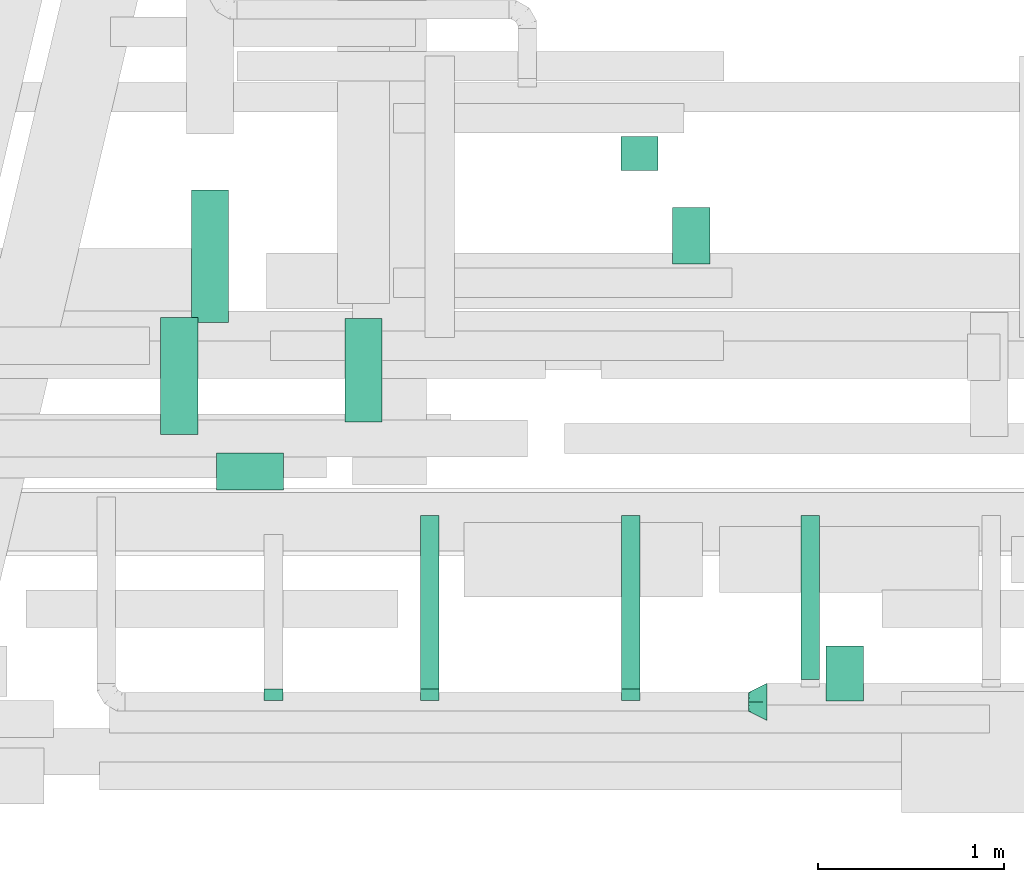
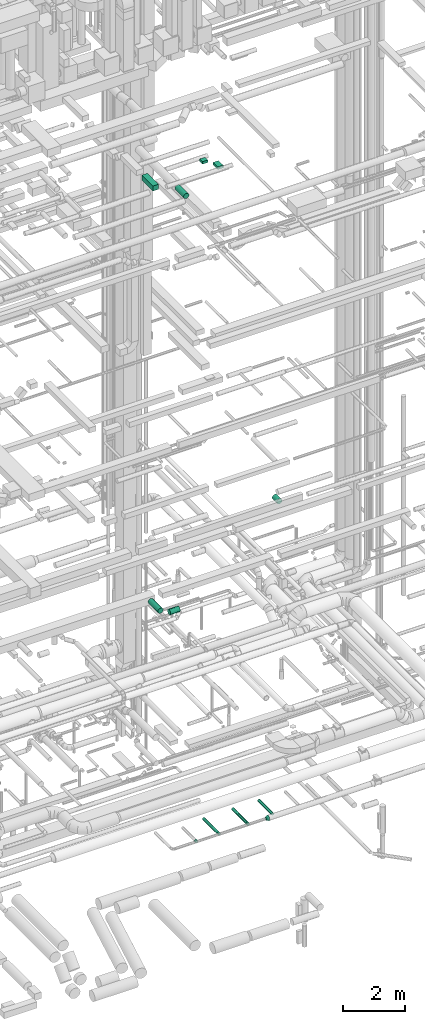
# One storey, part 205 of 337: 10 flow segments, 4 flow fittings.
"""IFC2X3 building model written with IfcOpenShell, lengths in millimetres."""

from ifc_helpers import new_model, entity, si_unit, converted_unit, derived_unit, direction, frame, origin, origin_2d_with_axis, place, context, subcontext, project, spatial, rectangle, circle, extrude, faceted_brep, source, transform, mapped, material, type_object, type_shapes, element, save


model = new_model("IFC2X3")

# Units and contexts
model_context = context("Model", 3, precision=0.01, world=origin(), true_north=direction((6.12303176911189e-17, 1.0)))
body_context = subcontext(model_context, "Body", "Model", "MODEL_VIEW")
ifc_project = project(units=[si_unit("LENGTHUNIT", "METRE", prefix="MILLI"), si_unit("AREAUNIT", "SQUARE_METRE"), si_unit("VOLUMEUNIT", "CUBIC_METRE"), converted_unit("PLANEANGLEUNIT", "DEGREE", entity("IfcRatioMeasure", 0.0174532925199433), si_unit("PLANEANGLEUNIT", "RADIAN"), dimensions=[0, 0, 0, 0, 0, 0, 0]), si_unit("MASSUNIT", "GRAM", prefix="KILO"), derived_unit("MASSDENSITYUNIT", [(si_unit("MASSUNIT", "GRAM", prefix="KILO"), 1), (si_unit("LENGTHUNIT", "METRE"), -3)]), derived_unit("MOMENTOFINERTIAUNIT", [(si_unit("LENGTHUNIT", "METRE"), 4)]), si_unit("TIMEUNIT", "SECOND"), si_unit("FREQUENCYUNIT", "HERTZ"), si_unit("THERMODYNAMICTEMPERATUREUNIT", "DEGREE_CELSIUS"), derived_unit("THERMALTRANSMITTANCEUNIT", [(si_unit("MASSUNIT", "GRAM", prefix="KILO"), 1), (si_unit("THERMODYNAMICTEMPERATUREUNIT", "KELVIN"), -1), (si_unit("TIMEUNIT", "SECOND"), -3)]), derived_unit("VOLUMETRICFLOWRATEUNIT", [(si_unit("LENGTHUNIT", "METRE"), 3), (si_unit("TIMEUNIT", "SECOND"), -1)]), derived_unit("MASSFLOWRATEUNIT", [(si_unit("MASSUNIT", "GRAM", prefix="KILO"), 1), (si_unit("TIMEUNIT", "SECOND"), -1)]), derived_unit("ROTATIONALFREQUENCYUNIT", [(si_unit("TIMEUNIT", "SECOND"), -1)]), si_unit("ELECTRICCURRENTUNIT", "AMPERE"), si_unit("ELECTRICVOLTAGEUNIT", "VOLT"), si_unit("POWERUNIT", "WATT"), si_unit("FORCEUNIT", "NEWTON", prefix="KILO"), si_unit("ILLUMINANCEUNIT", "LUX"), si_unit("LUMINOUSFLUXUNIT", "LUMEN"), si_unit("LUMINOUSINTENSITYUNIT", "CANDELA"), derived_unit("USERDEFINED", [(si_unit("MASSUNIT", "GRAM", prefix="KILO"), -1), (si_unit("LENGTHUNIT", "METRE"), -2), (si_unit("TIMEUNIT", "SECOND"), 3), (si_unit("LUMINOUSFLUXUNIT", "LUMEN"), 1)]), derived_unit("LINEARVELOCITYUNIT", [(si_unit("LENGTHUNIT", "METRE"), 1), (si_unit("TIMEUNIT", "SECOND"), -1)]), si_unit("PRESSUREUNIT", "PASCAL"), derived_unit("USERDEFINED", [(si_unit("LENGTHUNIT", "METRE"), -2), (si_unit("MASSUNIT", "GRAM", prefix="KILO"), 1), (si_unit("TIMEUNIT", "SECOND"), -2)]), derived_unit("LINEARFORCEUNIT", [(si_unit("MASSUNIT", "GRAM", prefix="KILO"), 1), (si_unit("LENGTHUNIT", "METRE"), 1), (si_unit("TIMEUNIT", "SECOND"), -2), (si_unit("LENGTHUNIT", "METRE"), -1)]), derived_unit("PLANARFORCEUNIT", [(si_unit("MASSUNIT", "GRAM", prefix="KILO"), 1), (si_unit("LENGTHUNIT", "METRE"), 1), (si_unit("TIMEUNIT", "SECOND"), -2), (si_unit("LENGTHUNIT", "METRE"), -2)])], contexts=[model_context])

# Site, building, storey
site_placement = place(None, origin())
site = spatial("IfcSite", under=ifc_project, at=site_placement, CompositionType="ELEMENT")
building_placement = place(site_placement, origin())
building = spatial("IfcBuilding", under=site, at=building_placement, CompositionType="ELEMENT")
storey_placement = place(building_placement, origin())
storey = spatial("IfcBuildingStorey", under=building, at=storey_placement, CompositionType="ELEMENT", Elevation=0.0)

# Flow segments
duct_segment_type_1 = type_object("IfcDuctSegmentType", PredefinedType="NOTDEFINED")
flow_segment_1_placement = place(storey_placement, frame((55079.59, 2900.97, 27450.0)))
element("IfcFlowSegment", 1, at=flow_segment_1_placement, inside=storey, type_object=duct_segment_type_1, context=body_context, shape_type="SweptSolid", body=[
    extrude(rectangle(XDim=711.276811598477, YDim=199.999999999998, at=origin_2d_with_axis()), frame((100.0, 355.64, 0.0), z_axis=(0.0, 0.0, 1.0), x_axis=(0.0, -1.0, 0.0)), (0.0, 0.0, 1.0), 199.999999999998),
])
flow_segment_2_placement = place(storey_placement, frame((57664.94, 3214.24, 27200.0)))
element("IfcFlowSegment", 2, at=flow_segment_2_placement, inside=storey, type_object=duct_segment_type_1, context=body_context, shape_type="SweptSolid", body=[
    extrude(rectangle(XDim=303.509978559031, YDim=199.999999999998, at=origin_2d_with_axis()), frame((100.0, 151.75, 0.0), z_axis=(0.0, 0.0, 1.0), x_axis=(0.0, 1.0, 0.0)), (0.0, 0.0, 1.0), 100.000000000003),
])
flow_segment_3_placement = place(storey_placement, frame((57387.09, 3718.31, 27200.0)))
element("IfcFlowSegment", 3, at=flow_segment_3_placement, inside=storey, type_object=duct_segment_type_1, context=body_context, shape_type="SweptSolid", body=[
    extrude(rectangle(XDim=179.999999999986, YDim=199.999999999998, at=origin_2d_with_axis()), frame((100.0, 90.0, 0.0), z_axis=(0.0, 0.0, 1.0), x_axis=(0.0, -1.0, 0.0)), (0.0, 0.0, 1.0), 100.000000000003),
])
duct_segment_type_2 = type_object("IfcDuctSegmentType", PredefinedType="NOTDEFINED")
flow_segment_4_placement = place(storey_placement, frame((55214.11, 1997.57, 11298.4)))
element("IfcFlowSegment", 4, at=flow_segment_4_placement, inside=storey, type_object=duct_segment_type_2, context=body_context, shape_type="SweptSolid", body=[
    extrude(circle(Radius=100.0, at=origin_2d_with_axis()), frame((0.0, 101.6, 101.6), z_axis=(1.0, 0.0, 0.0), x_axis=(0.0, -1.0, 0.0)), (0.0, 0.0, 1.0), 359.999999999961),
])
flow_segment_5_placement = place(storey_placement, frame((54912.51, 2299.16, 11298.4)))
element("IfcFlowSegment", 5, at=flow_segment_5_placement, inside=storey, type_object=duct_segment_type_2, context=body_context, shape_type="SweptSolid", body=[
    extrude(circle(Radius=100.0, at=origin_2d_with_axis()), frame((101.6, 0.0, 101.6), z_axis=(0.0, 1.0, 0.0), x_axis=(-1.0, 0.0, 0.0)), (0.0, 0.0, 1.0), 628.712130819277),
])
flow_segment_6_placement = place(storey_placement, frame((58488.6, 865.66, 15198.4)))
element("IfcFlowSegment", 6, at=flow_segment_6_placement, inside=storey, type_object=duct_segment_type_2, context=body_context, shape_type="SweptSolid", body=[
    extrude(circle(Radius=100.0, at=origin_2d_with_axis()), frame((101.6, 0.0, 101.6), z_axis=(0.0, 1.0, 0.0), x_axis=(-1.0, 0.0, 0.0)), (0.0, 0.0, 1.0), 296.742634045113),
])
flow_segment_7_placement = place(storey_placement, frame((55903.34, 2365.61, 27158.4)))
element("IfcFlowSegment", 7, at=flow_segment_7_placement, inside=storey, type_object=duct_segment_type_2, context=body_context, shape_type="SweptSolid", body=[
    extrude(circle(Radius=100.0, at=origin_2d_with_axis()), frame((101.6, 0.0, 101.6), z_axis=(0.0, 1.0, 0.0), x_axis=(-1.0, 0.0, 0.0)), (0.0, 0.0, 1.0), 557.500000000001),
])
flow_segment_8_placement = place(storey_placement, frame((56309.27, 932.18, 2998.4)))
element("IfcFlowSegment", 8, at=flow_segment_8_placement, inside=storey, type_object=duct_segment_type_2, context=body_context, shape_type="SweptSolid", body=[
    extrude(circle(Radius=50.0, at=origin_2d_with_axis()), frame((51.6, 0.0, 51.6), z_axis=(0.0, 1.0, 0.0), x_axis=(1.0, 0.0, 0.0)), (0.0, 0.0, 1.0), 930.000000000234),
])
flow_segment_9_placement = place(storey_placement, frame((57389.27, 932.18, 2998.4)))
element("IfcFlowSegment", 9, at=flow_segment_9_placement, inside=storey, type_object=duct_segment_type_2, context=body_context, shape_type="SweptSolid", body=[
    extrude(circle(Radius=50.0, at=origin_2d_with_axis()), frame((51.6, 0.0, 51.6), z_axis=(0.0, 1.0, 0.0), x_axis=(1.0, 0.0, 0.0)), (0.0, 0.0, 1.0), 930.000000000324),
])
flow_segment_10_placement = place(storey_placement, frame((58353.51, 982.18, 2998.4)))
element("IfcFlowSegment", 10, at=flow_segment_10_placement, inside=storey, type_object=duct_segment_type_2, context=body_context, shape_type="SweptSolid", body=[
    extrude(circle(Radius=50.0, at=origin_2d_with_axis()), frame((51.6, 0.0, 51.6), z_axis=(0.0, 1.0, 0.0), x_axis=(1.0, 0.0, 0.0)), (0.0, 0.0, 1.0), 880.000000000402),
])

# Flow fittings
ifc_material = material()
duct_fitting_type_1 = type_object("IfcDuctFittingType", PredefinedType="NOTDEFINED", material=ifc_material)
shared_shape_1 = source(origin(), body_context, "Body", "Brep", [
    faceted_brep([(20.0, 0.0, -50.0), (20.0, 12.94, -48.3), (20.0, 25.0, -43.3), (20.0, 35.36, -35.36), (20.0, 43.3, -25.0), (20.0, 48.3, -12.94), (20.0, 50.0, 0.0), (20.0, 48.3, 12.94), (20.0, 43.3, 25.0), (20.0, 35.36, 35.36), (20.0, 25.0, 43.3), (20.0, 12.94, 48.3), (20.0, 0.0, 50.0), (20.0, -12.94, 48.3), (20.0, -25.0, 43.3), (20.0, -35.36, 35.36), (20.0, -43.3, 25.0), (20.0, -48.3, 12.94), (20.0, -50.0, 0.0), (20.0, -48.3, -12.94), (20.0, -43.3, -25.0), (20.0, -35.36, -35.36), (20.0, -25.0, -43.3), (20.0, -12.94, -48.3), (0.0, 0.0, 50.0), (-43.9, 0.0, 50.0), (-43.9, -12.94, 48.3), (0.0, -12.94, 48.3), (-43.9, -25.0, 43.3), (0.0, -25.0, 43.3), (0.0, -35.36, 35.36), (-43.9, -35.36, 35.36), (0.0, -43.3, 25.0), (-43.9, -43.3, 25.0), (-43.9, -48.3, 12.94), (0.0, -48.3, 12.94), (-43.9, -50.0, 0.0), (0.0, -50.0, 0.0), (-43.9, -48.3, -12.94), (0.0, -48.3, -12.94), (-43.9, -43.3, -25.0), (0.0, -43.3, -25.0), (0.0, -35.36, -35.36), (-43.9, -35.36, -35.36), (0.0, -25.0, -43.3), (-43.9, -25.0, -43.3), (-43.9, -12.94, -48.3), (0.0, -12.94, -48.3), (-43.9, 0.0, -50.0), (0.0, 0.0, -50.0), (-43.9, 12.94, -48.3), (0.0, 12.94, -48.3), (-43.9, 25.0, -43.3), (0.0, 25.0, -43.3), (0.0, 35.36, -35.36), (-43.9, 35.36, -35.36), (0.0, 43.3, -25.0), (-43.9, 43.3, -25.0), (-43.9, 48.3, -12.94), (0.0, 48.3, -12.94), (-43.9, 50.0, 0.0), (0.0, 50.0, 0.0), (-43.9, 48.3, 12.94), (0.0, 48.3, 12.94), (-43.9, 43.3, 25.0), (0.0, 43.3, 25.0), (0.0, 35.36, 35.36), (-43.9, 35.36, 35.36), (0.0, 25.0, 43.3), (-43.9, 25.0, 43.3), (-43.9, 12.94, 48.3), (0.0, 12.94, 48.3)], [[[0, 1, 2, 3, 4, 5, 6, 7, 8, 9, 10, 11, 12, 13, 14, 15, 16, 17, 18, 19, 20, 21, 22, 23]], [[13, 12, 24, 25, 26, 27]], [[14, 13, 27, 26, 28, 29]], [[30, 15, 14, 29, 28, 31]], [[17, 16, 32, 33, 34, 35]], [[18, 17, 35, 34, 36, 37]], [[32, 16, 15, 30, 31, 33]], [[19, 18, 37, 36, 38, 39]], [[20, 19, 39, 38, 40, 41]], [[42, 21, 20, 41, 40, 43]], [[23, 22, 44, 45, 46, 47]], [[0, 23, 47, 46, 48, 49]], [[44, 22, 21, 42, 43, 45]], [[1, 0, 49, 48, 50, 51]], [[2, 1, 51, 50, 52, 53]], [[54, 3, 2, 53, 52, 55]], [[5, 4, 56, 57, 58, 59]], [[6, 5, 59, 58, 60, 61]], [[56, 4, 3, 54, 55, 57]], [[7, 6, 61, 60, 62, 63]], [[8, 7, 63, 62, 64, 65]], [[66, 9, 8, 65, 64, 67]], [[11, 10, 68, 69, 70, 71]], [[12, 11, 71, 70, 25, 24]], [[68, 10, 9, 66, 67, 69]], [[46, 45, 43, 40, 38, 36, 34, 33, 31, 28, 26, 25, 70, 69, 67, 64, 62, 60, 58, 57, 55, 52, 50, 48]]]),
])
type_shapes(duct_fitting_type_1, [shared_shape_1])
for number, where, z_axis, x_axis in (
    (11, (55520.86, 912.18, 3050.0), (0.0, 0.0, -1.0), (0.0, 1.0, 0.0)),
    (12, (56360.86, 912.18, 3050.0), (0.0, 0.0, -1.0), (0.0, 1.0, 0.0)),
    (13, (57440.86, 912.18, 3050.0), (0.0, 0.0, -1.0), (0.0, 1.0, 0.0)),
):
    element("IfcFlowFitting", number, at=place(storey_placement, frame(where, z_axis=z_axis, x_axis=x_axis)), inside=storey, type_object=duct_fitting_type_1, material=ifc_material, context=body_context, shape_type="MappedRepresentation", body=[
        mapped(shared_shape_1, transform((0.0, 0.0, 0.0), scale=1.0)),
    ])
duct_fitting_type_2 = type_object("IfcDuctFittingType", PredefinedType="NOTDEFINED", material=ifc_material)
shared_shape_2 = source(origin(), body_context, "Body", "Brep", [
    faceted_brep([(100.0, -58.78, -80.9), (100.0, -30.9, -95.11), (100.0, 0.0, -100.0), (100.0, 30.9, -95.11), (100.0, 58.78, -80.9), (100.0, 80.9, -58.78), (100.0, 95.11, -30.9), (100.0, 100.0, 0.0), (100.0, 95.11, 30.9), (100.0, 80.9, 58.78), (100.0, 58.78, 80.9), (100.0, 30.9, 95.11), (100.0, 0.0, 100.0), (100.0, -30.9, 95.11), (100.0, -58.78, 80.9), (100.0, -80.9, 58.78), (100.0, -95.11, 30.9), (100.0, -100.0, 0.0), (100.0, -95.11, -30.9), (100.0, -80.9, -58.78), (0.0, -19.13, -46.19), (0.0, -27.24, -40.77), (0.0, -35.36, -35.36), (0.0, -40.77, -27.24), (0.0, -46.19, -19.13), (0.0, -48.1, -9.57), (0.0, -50.0, 0.0), (0.0, -48.1, 9.57), (0.0, -46.19, 19.13), (0.0, -40.77, 27.24), (0.0, -35.36, 35.36), (0.0, -27.24, 40.77), (0.0, -19.13, 46.19), (0.0, -9.57, 48.1), (0.0, 0.0, 50.0), (0.0, 9.57, 48.1), (0.0, 19.13, 46.19), (0.0, 27.24, 40.77), (0.0, 35.36, 35.36), (0.0, 40.77, 27.24), (0.0, 46.19, 19.13), (0.0, 48.1, 9.57), (0.0, 50.0, 0.0), (0.0, 48.1, -9.57), (0.0, 46.19, -19.13), (0.0, 40.77, -27.24), (0.0, 35.36, -35.36), (0.0, 27.24, -40.77), (0.0, 19.13, -46.19), (0.0, 9.57, -48.1), (0.0, 0.0, -50.0), (0.0, -9.57, -48.1)], [[[0, 1, 2, 3, 4, 5, 6, 7, 8, 9, 10, 11, 12, 13, 14, 15, 16, 17, 18, 19]], [[20, 21, 22, 23, 24, 25, 26, 27, 28, 29, 30, 31, 32, 33, 34, 35, 36, 37, 38, 39, 40, 41, 42, 43, 44, 45, 46, 47, 48, 49, 50, 51]], [[7, 41, 8]], [[41, 7, 42]], [[40, 9, 8]], [[11, 36, 35]], [[41, 40, 8]], [[9, 40, 39, 38]], [[10, 38, 37, 36]], [[12, 35, 34]], [[11, 10, 36]], [[12, 11, 35]], [[38, 10, 9]], [[12, 33, 13]], [[33, 12, 34]], [[32, 14, 13]], [[16, 28, 27]], [[33, 32, 13]], [[14, 32, 31, 30]], [[15, 30, 29, 28]], [[17, 27, 26]], [[16, 15, 28]], [[17, 16, 27]], [[30, 15, 14]], [[17, 25, 18]], [[25, 17, 26]], [[24, 19, 18]], [[1, 20, 51]], [[25, 24, 18]], [[19, 24, 23, 22]], [[0, 22, 21, 20]], [[2, 51, 50]], [[1, 0, 20]], [[2, 1, 51]], [[22, 0, 19]], [[2, 49, 3]], [[49, 2, 50]], [[48, 4, 3]], [[6, 44, 43]], [[49, 48, 3]], [[4, 48, 47, 46]], [[5, 46, 45, 44]], [[7, 43, 42]], [[6, 5, 44]], [[7, 6, 43]], [[46, 5, 4]]]),
])
type_shapes(duct_fitting_type_2, [shared_shape_2])
flow_fitting_placement = place(storey_placement, frame((58072.5, 862.18, 3050.0)))
element("IfcFlowFitting", 14, at=flow_fitting_placement, inside=storey, type_object=duct_fitting_type_2, material=ifc_material, context=body_context, shape_type="MappedRepresentation", body=[
    mapped(shared_shape_2, transform((0.0, 0.0, 0.0), scale=1.0)),
])

save(model, "model.ifc")
